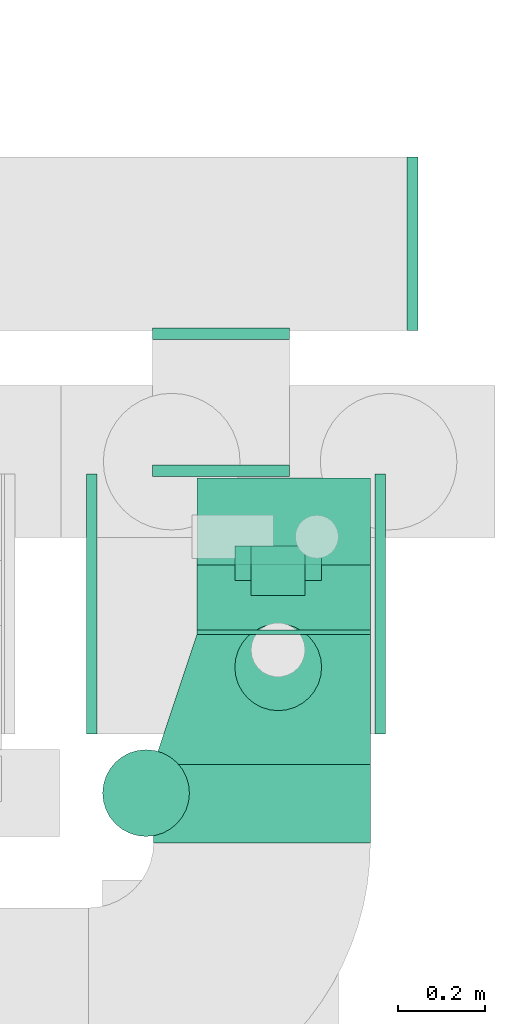
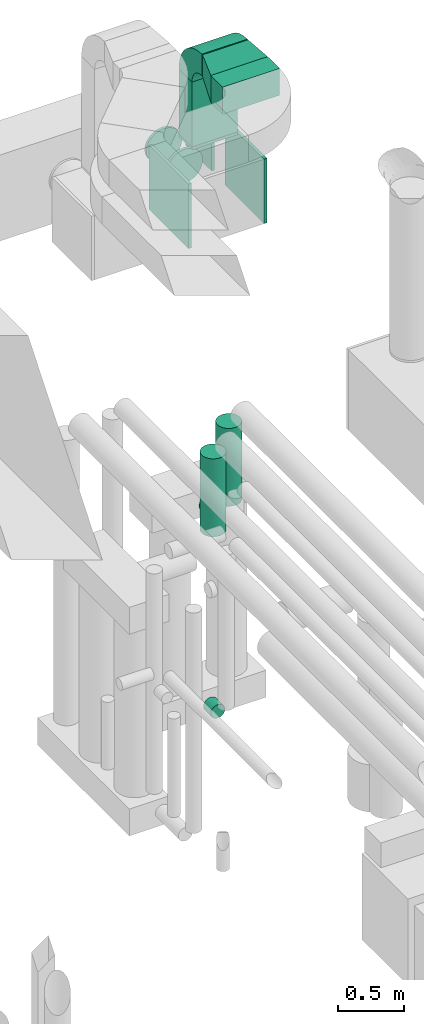
# One storey, part 312 of 337: 8 flow fittings, 7 flow segments.
"""IFC2X3 building model written with IfcOpenShell, lengths in millimetres."""

from ifc_helpers import new_model, entity, si_unit, converted_unit, derived_unit, direction, frame, frame_2d, origin, origin_2d_with_axis, place, context, subcontext, project, spatial, polyline, circle_curve, parameter, trimmed, segment, composite_curve, rectangle, circle, outline, extrude, faceted_brep, source, transform, mapped, material, type_object, type_shapes, element, save


model = new_model("IFC2X3")

# Units and contexts
model_context = context("Model", 3, precision=0.01, world=origin(), true_north=direction((6.12303176911189e-17, 1.0)))
body_context = subcontext(model_context, "Body", "Model", "MODEL_VIEW")
ifc_project = project(units=[si_unit("LENGTHUNIT", "METRE", prefix="MILLI"), si_unit("AREAUNIT", "SQUARE_METRE"), si_unit("VOLUMEUNIT", "CUBIC_METRE"), converted_unit("PLANEANGLEUNIT", "DEGREE", entity("IfcRatioMeasure", 0.0174532925199433), si_unit("PLANEANGLEUNIT", "RADIAN"), dimensions=[0, 0, 0, 0, 0, 0, 0]), si_unit("MASSUNIT", "GRAM", prefix="KILO"), derived_unit("MASSDENSITYUNIT", [(si_unit("MASSUNIT", "GRAM", prefix="KILO"), 1), (si_unit("LENGTHUNIT", "METRE"), -3)]), derived_unit("MOMENTOFINERTIAUNIT", [(si_unit("LENGTHUNIT", "METRE"), 4)]), si_unit("TIMEUNIT", "SECOND"), si_unit("FREQUENCYUNIT", "HERTZ"), si_unit("THERMODYNAMICTEMPERATUREUNIT", "DEGREE_CELSIUS"), derived_unit("THERMALTRANSMITTANCEUNIT", [(si_unit("MASSUNIT", "GRAM", prefix="KILO"), 1), (si_unit("THERMODYNAMICTEMPERATUREUNIT", "KELVIN"), -1), (si_unit("TIMEUNIT", "SECOND"), -3)]), derived_unit("VOLUMETRICFLOWRATEUNIT", [(si_unit("LENGTHUNIT", "METRE"), 3), (si_unit("TIMEUNIT", "SECOND"), -1)]), derived_unit("MASSFLOWRATEUNIT", [(si_unit("MASSUNIT", "GRAM", prefix="KILO"), 1), (si_unit("TIMEUNIT", "SECOND"), -1)]), derived_unit("ROTATIONALFREQUENCYUNIT", [(si_unit("TIMEUNIT", "SECOND"), -1)]), si_unit("ELECTRICCURRENTUNIT", "AMPERE"), si_unit("ELECTRICVOLTAGEUNIT", "VOLT"), si_unit("POWERUNIT", "WATT"), si_unit("FORCEUNIT", "NEWTON", prefix="KILO"), si_unit("ILLUMINANCEUNIT", "LUX"), si_unit("LUMINOUSFLUXUNIT", "LUMEN"), si_unit("LUMINOUSINTENSITYUNIT", "CANDELA"), derived_unit("USERDEFINED", [(si_unit("MASSUNIT", "GRAM", prefix="KILO"), -1), (si_unit("LENGTHUNIT", "METRE"), -2), (si_unit("TIMEUNIT", "SECOND"), 3), (si_unit("LUMINOUSFLUXUNIT", "LUMEN"), 1)]), derived_unit("LINEARVELOCITYUNIT", [(si_unit("LENGTHUNIT", "METRE"), 1), (si_unit("TIMEUNIT", "SECOND"), -1)]), si_unit("PRESSUREUNIT", "PASCAL"), derived_unit("USERDEFINED", [(si_unit("LENGTHUNIT", "METRE"), -2), (si_unit("MASSUNIT", "GRAM", prefix="KILO"), 1), (si_unit("TIMEUNIT", "SECOND"), -2)]), derived_unit("LINEARFORCEUNIT", [(si_unit("MASSUNIT", "GRAM", prefix="KILO"), 1), (si_unit("LENGTHUNIT", "METRE"), 1), (si_unit("TIMEUNIT", "SECOND"), -2), (si_unit("LENGTHUNIT", "METRE"), -1)]), derived_unit("PLANARFORCEUNIT", [(si_unit("MASSUNIT", "GRAM", prefix="KILO"), 1), (si_unit("LENGTHUNIT", "METRE"), 1), (si_unit("TIMEUNIT", "SECOND"), -2), (si_unit("LENGTHUNIT", "METRE"), -2)])], contexts=[model_context])

# Site, building, storey
site_placement = place(None, origin())
site = spatial("IfcSite", under=ifc_project, at=site_placement, CompositionType="ELEMENT")
building_placement = place(site_placement, origin())
building = spatial("IfcBuilding", under=site, at=building_placement, CompositionType="ELEMENT")
storey_placement = place(building_placement, origin())
storey = spatial("IfcBuildingStorey", under=building, at=storey_placement, CompositionType="ELEMENT", Elevation=0.0)

# Flow segments
duct_segment_type_1 = type_object("IfcDuctSegmentType", PredefinedType="NOTDEFINED")
flow_segment_1_placement = place(storey_placement, frame((72531.11, 16403.61, 33870.0)))
element("IfcFlowSegment", 1, at=flow_segment_1_placement, inside=storey, type_object=duct_segment_type_1, context=body_context, shape_type="SweptSolid", body=[
    extrude(rectangle(XDim=200.000000000002, YDim=399.999999999996, at=origin_2d_with_axis()), frame((200.0, 100.0, 0.0), z_axis=(0.0, 0.0, 1.0), x_axis=(0.0, -1.0, 0.0)), (0.0, 0.0, 1.0), 605.000000000174),
])
flow_segment_2_placement = place(storey_placement, frame((72431.11, 15763.0, 34600.0)))
element("IfcFlowSegment", 2, at=flow_segment_2_placement, inside=storey, type_object=duct_segment_type_1, context=body_context, shape_type="SweptSolid", body=[
    extrude(rectangle(XDim=180.609160050673, YDim=499.999999999999, at=origin_2d_with_axis()), frame((250.0, 90.3, 0.0), z_axis=(0.0, 0.0, 1.0), x_axis=(0.0, 1.0, 0.0)), (0.0, 0.0, 1.0), 250.000000000004),
])
flow_segment_3_placement = place(storey_placement, frame((72531.11, 16243.61, 34625.0)))
element("IfcFlowSegment", 3, at=flow_segment_3_placement, inside=storey, type_object=duct_segment_type_1, context=body_context, shape_type="SweptSolid", body=[
    extrude(rectangle(XDim=9.9999999999934, YDim=399.999999999996, at=origin_2d_with_axis()), frame((200.0, 5.0, 0.0), z_axis=(0.0, 0.0, 1.0), x_axis=(0.0, -1.0, 0.0)), (0.0, 0.0, 1.0), 199.999999999998),
])
duct_segment_type_2 = type_object("IfcDuctSegmentType", PredefinedType="NOTDEFINED")
flow_segment_4_placement = place(storey_placement, frame((72616.89, 16066.15, 30676.25)))
element("IfcFlowSegment", 4, at=flow_segment_4_placement, inside=storey, type_object=duct_segment_type_2, context=body_context, shape_type="SweptSolid", body=[
    extrude(circle(Radius=100.0, at=origin_2d_with_axis()), frame((101.6, 101.6, 0.0)), (0.0, 0.0, 1.0), 723.750000000004),
])
flow_segment_5_placement = place(storey_placement, frame((72616.89, 16367.75, 30374.65)))
element("IfcFlowSegment", 5, at=flow_segment_5_placement, inside=storey, type_object=duct_segment_type_2, context=body_context, shape_type="SweptSolid", body=[
    extrude(circle(Radius=100.0, at=origin_2d_with_axis()), frame((101.6, 0.0, 101.6), z_axis=(0.0, 1.0, 0.0), x_axis=(1.0, 0.0, 0.0)), (0.0, 0.0, 1.0), 78.949323229976),
])
flow_segment_6_placement = place(storey_placement, frame((72312.2, 15776.15, 30675.0)))
element("IfcFlowSegment", 6, at=flow_segment_6_placement, inside=storey, type_object=duct_segment_type_2, context=body_context, shape_type="SweptSolid", body=[
    extrude(circle(Radius=100.0, at=origin_2d_with_axis()), frame((101.6, 101.6, 0.0)), (0.0, 0.0, 1.0), 725.000000000034),
])
flow_segment_7_placement = place(storey_placement, frame((72653.96, 16332.74, 28535.9)))
element("IfcFlowSegment", 7, at=flow_segment_7_placement, inside=storey, type_object=duct_segment_type_2, context=body_context, shape_type="SweptSolid", body=[
    extrude(circle(Radius=62.5, at=origin_2d_with_axis()), frame((64.1, 0.0, 64.1), z_axis=(0.0, 1.0, 0.0), x_axis=(1.0, 0.0, 0.0)), (0.0, 0.0, 1.0), 113.954109372131),
])

# Flow fittings
ifc_material = material()
duct_fitting_type_1 = type_object("IfcDuctFittingType", PredefinedType="NOTDEFINED", material=ifc_material)
shared_shape_1 = source(origin(), body_context, "Body", "SweptSolid", [
    extrude(rectangle(XDim=200.0, YDim=26.096, at=origin_2d_with_axis()), frame((6.95, 0.0, -200.0), z_axis=(0.0, 0.0, 1.0), x_axis=(0.0, -1.0, 0.0)), (0.0, 0.0, 1.0), 400.0),
])
type_shapes(duct_fitting_type_1, [shared_shape_1])
flow_fitting_1_placement = place(storey_placement, frame((72731.11, 16503.61, 33850.0), z_axis=(1.0, 0.0, 0.0), x_axis=(0.0, 0.0, 1.0)))
element("IfcFlowFitting", 8, at=flow_fitting_1_placement, inside=storey, type_object=duct_fitting_type_1, material=ifc_material, context=body_context, shape_type="MappedRepresentation", body=[
    mapped(shared_shape_1, transform((0.0, 0.0, 0.0), scale=1.0)),
])
duct_fitting_type_2 = type_object("IfcDuctFittingType", PredefinedType="NOTDEFINED", material=ifc_material)
shared_shape_2 = source(origin(), body_context, "Body", "SweptSolid", [
    extrude(rectangle(XDim=24.9999999999999, YDim=600.0, at=origin_2d_with_axis()), frame((12.5, 0.0, -300.0)), (0.0, 0.0, 1.0), 600.0),
])
type_shapes(duct_fitting_type_2, [shared_shape_2])
flow_fitting_2_placement = place(storey_placement, frame((72941.11, 16313.61, 33550.0)))
element("IfcFlowFitting", 9, at=flow_fitting_2_placement, inside=storey, type_object=duct_fitting_type_2, material=ifc_material, context=body_context, shape_type="MappedRepresentation", body=[
    mapped(shared_shape_2, transform((0.0, 0.0, 0.0), scale=1.0)),
])
flow_fitting_3_placement = place(storey_placement, frame((72301.11, 16313.61, 33550.0), z_axis=(0.0, 0.0, 1.0), x_axis=(-1.0, 0.0, 0.0)))
element("IfcFlowFitting", 10, at=flow_fitting_3_placement, inside=storey, type_object=duct_fitting_type_2, material=ifc_material, context=body_context, shape_type="MappedRepresentation", body=[
    mapped(shared_shape_2, transform((0.0, 0.0, 0.0), scale=1.0)),
])
duct_fitting_type_3 = type_object("IfcDuctFittingType", PredefinedType="NOTDEFINED", material=ifc_material)
shared_shape_3 = source(origin(), body_context, "Body", "SweptSolid", [
    extrude(rectangle(XDim=24.9999999999999, YDim=400.0, at=origin_2d_with_axis()), frame((12.5, 0.0, -400.0)), (0.0, 0.0, 1.0), 800.0),
])
type_shapes(duct_fitting_type_3, [shared_shape_3])
flow_fitting_4_placement = place(storey_placement, frame((73015.37, 17143.61, 33550.0)))
element("IfcFlowFitting", 11, at=flow_fitting_4_placement, inside=storey, type_object=duct_fitting_type_3, material=ifc_material, context=body_context, shape_type="MappedRepresentation", body=[
    mapped(shared_shape_3, transform((0.0, 0.0, 0.0), scale=1.0)),
])
duct_fitting_type_4 = type_object("IfcDuctFittingType", PredefinedType="NOTDEFINED", material=ifc_material)
shared_shape_4 = source(origin(), body_context, "Body", "Brep", [
    faceted_brep([(20.0, 40.76, -152.13), (20.0, 78.75, -136.4), (20.0, 111.37, -111.37), (20.0, 136.4, -78.75), (20.0, 152.13, -40.76), (20.0, 157.5, 0.0), (20.0, 152.13, 40.76), (20.0, 136.4, 78.75), (20.0, 111.37, 111.37), (20.0, 78.75, 136.4), (20.0, 40.76, 152.13), (20.0, 0.0, 157.5), (20.0, -40.76, 152.13), (20.0, -78.75, 136.4), (20.0, -111.37, 111.37), (20.0, -136.4, 78.75), (20.0, -152.13, 40.76), (20.0, -157.5, 0.0), (20.0, -152.13, -40.76), (20.0, -136.4, -78.75), (20.0, -111.37, -111.37), (20.0, -78.75, -136.4), (20.0, -40.76, -152.13), (20.0, 0.0, -157.5), (0.0, 0.0, 157.5), (0.0, 40.76, 152.13), (-6.1, 40.76, 152.13), (-6.1, 0.0, 157.5), (0.0, 78.75, 136.4), (-6.1, 78.75, 136.4), (0.0, 111.37, 111.37), (-6.1, 111.37, 111.37), (0.0, 136.4, 78.75), (0.0, 152.13, 40.76), (-6.1, 152.13, 40.76), (-6.1, 136.4, 78.75), (0.0, 157.5, 0.0), (-6.1, 157.5, 0.0), (0.0, 152.13, -40.76), (-6.1, 152.13, -40.76), (0.0, 136.4, -78.75), (-6.1, 136.4, -78.75), (0.0, 111.37, -111.37), (-6.1, 111.37, -111.37), (0.0, 0.0, -157.5), (-6.1, 0.0, -157.5), (-6.1, 40.76, -152.13), (0.0, 40.76, -152.13), (-6.1, 78.75, -136.4), (0.0, 78.75, -136.4), (0.0, -40.76, -152.13), (-6.1, -40.76, -152.13), (0.0, -78.75, -136.4), (-6.1, -78.75, -136.4), (0.0, -111.37, -111.37), (-6.1, -111.37, -111.37), (0.0, -136.4, -78.75), (0.0, -152.13, -40.76), (-6.1, -152.13, -40.76), (-6.1, -136.4, -78.75), (0.0, -157.5, 0.0), (-6.1, -157.5, 0.0), (0.0, -152.13, 40.76), (-6.1, -152.13, 40.76), (0.0, -136.4, 78.75), (-6.1, -136.4, 78.75), (0.0, -111.37, 111.37), (-6.1, -111.37, 111.37), (0.0, -78.75, 136.4), (0.0, -40.76, 152.13), (-6.1, -40.76, 152.13), (-6.1, -78.75, 136.4)], [[[0, 1, 2, 3, 4, 5, 6, 7, 8, 9, 10, 11, 12, 13, 14, 15, 16, 17, 18, 19, 20, 21, 22, 23]], [[24, 11, 10, 25, 26, 27]], [[25, 10, 9, 28, 29, 26]], [[28, 9, 8, 30, 31, 29]], [[32, 7, 6, 33, 34, 35]], [[33, 6, 5, 36, 37, 34]], [[30, 8, 7, 32, 35, 31]], [[36, 5, 4, 38, 39, 37]], [[38, 4, 3, 40, 41, 39]], [[40, 3, 2, 42, 43, 41]], [[0, 23, 44, 45, 46, 47]], [[1, 0, 47, 46, 48, 49]], [[49, 48, 43, 42, 2, 1]], [[44, 23, 22, 50, 51, 45]], [[50, 22, 21, 52, 53, 51]], [[52, 21, 20, 54, 55, 53]], [[56, 19, 18, 57, 58, 59]], [[57, 18, 17, 60, 61, 58]], [[54, 20, 19, 56, 59, 55]], [[60, 17, 16, 62, 63, 61]], [[62, 16, 15, 64, 65, 63]], [[64, 15, 14, 66, 67, 65]], [[68, 13, 12, 69, 70, 71]], [[69, 12, 11, 24, 27, 70]], [[66, 14, 13, 68, 71, 67]], [[45, 51, 53, 55, 59, 58, 61, 63, 65, 67, 71, 70, 27, 26, 29, 31, 35, 34, 37, 39, 41, 43, 48, 46]]]),
])
type_shapes(duct_fitting_type_4, [shared_shape_4])
for number, where, z_axis, x_axis in (
    (12, (72586.53, 16613.61, 33550.0), (0.0, 0.0, -1.0), (0.0, 1.0, 0.0)),
    (13, (72586.53, 16943.61, 33550.0), (0.0, 0.0, -1.0), (0.0, -1.0, 0.0)),
):
    element("IfcFlowFitting", number, at=place(storey_placement, frame(where, z_axis=z_axis, x_axis=x_axis)), inside=storey, type_object=duct_fitting_type_4, material=ifc_material, context=body_context, shape_type="MappedRepresentation", body=[
        mapped(shared_shape_4, transform((0.0, 0.0, 0.0), scale=1.0)),
    ])
duct_fitting_type_5 = type_object("IfcDuctFittingType", PredefinedType="NOTDEFINED", material=ifc_material)
shared_shape_5 = source(origin(), body_context, "Body", "Brep", [
    faceted_brep([(300.0, -250.0, 100.0), (300.0, -250.0, -100.0), (300.0, 150.0, -100.0), (300.0, 150.0, 100.0), (0.0, -250.0, 125.0), (0.0, 250.0, 125.0), (0.0, 250.0, -125.0), (0.0, -250.0, -125.0)], [[[0, 1, 2, 3]], [[4, 5, 6, 7]], [[4, 7, 1, 0]], [[7, 6, 2, 1]], [[6, 5, 3, 2]], [[5, 4, 0, 3]]]),
])
type_shapes(duct_fitting_type_5, [shared_shape_5])
flow_fitting_5_placement = place(storey_placement, frame((72681.11, 15943.61, 34725.0), z_axis=(0.0, 0.0, 1.0), x_axis=(0.0, 1.0, 0.0)))
element("IfcFlowFitting", 14, at=flow_fitting_5_placement, inside=storey, type_object=duct_fitting_type_5, material=ifc_material, context=body_context, shape_type="MappedRepresentation", body=[
    mapped(shared_shape_5, transform((0.0, 0.0, 0.0), scale=1.0)),
])
duct_fitting_type_6 = type_object("IfcDuctFittingType", PredefinedType="NOTDEFINED", material=ifc_material)
shared_shape_6 = source(origin(), body_context, "Body", "SweptSolid", [
    extrude(outline(composite_curve([segment(polyline([(-225.0, -125.0), (-25.0, -125.0)]), True, "CONTINUOUS"), segment(trimmed(circle_curve(frame_2d((125.0, -125.0), x_axis=(0.0, 1.0)), 150.0), [parameter(0.0)], [parameter(90.0000000000001)], True, "PARAMETER"), False, "CONTINUOUS"), segment(polyline([(125.0, 25.0), (125.0, 225.0)]), True, "CONTINUOUS"), segment(trimmed(circle_curve(frame_2d((125.0, -125.0), x_axis=(0.0, 1.0)), 350.0), [parameter(0.0)], [parameter(90.0000000000001)], True, "PARAMETER"), True, "CONTINUOUS")], self_intersect=False)), frame((-125.0, 125.0, -200.0), z_axis=(0.0, 0.0, 1.0), x_axis=(-1.0, 0.0, 0.0)), (0.0, 0.0, 1.0), 400.0),
])
type_shapes(duct_fitting_type_6, [shared_shape_6])
flow_fitting_6_placement = place(storey_placement, frame((72731.11, 16503.61, 34725.0), z_axis=(1.0, 0.0, 0.0), x_axis=(0.0, 0.0, 1.0)))
element("IfcFlowFitting", 15, at=flow_fitting_6_placement, inside=storey, type_object=duct_fitting_type_6, material=ifc_material, context=body_context, shape_type="MappedRepresentation", body=[
    mapped(shared_shape_6, transform((0.0, 0.0, 0.0), scale=1.0)),
])

save(model, "model.ifc")
